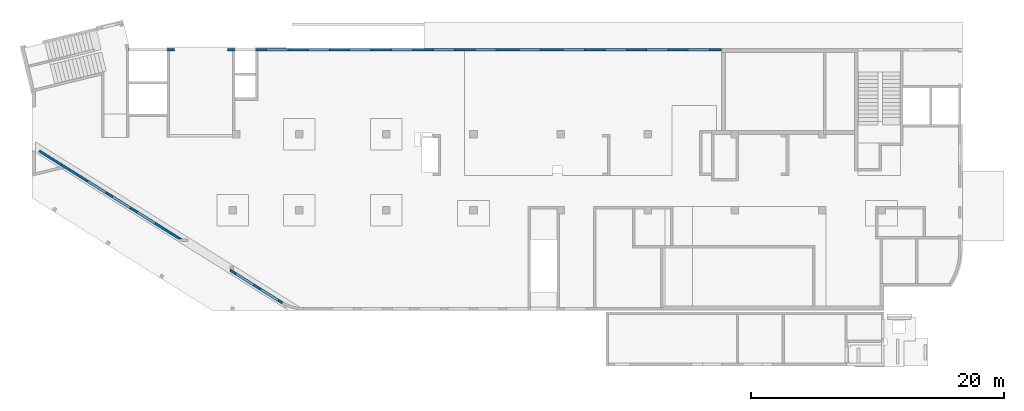
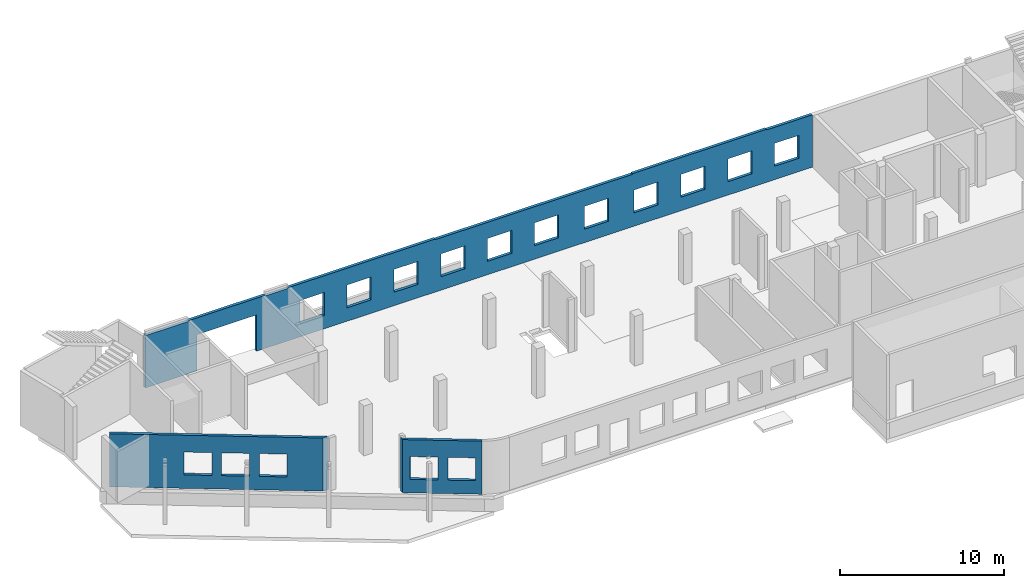
# One storey, part 6 of 8: 3 walls, 18 openings.
"""IFC4 building model written with IfcOpenShell, lengths in millimetres."""

from ifc_helpers import new_model, entity, si_unit, converted_unit, derived_unit, direction, frame, origin, place, context, subcontext, project, spatial, indexed_curve, outline, extrude, polygons, material, type_object, element, save


model = new_model("IFC4")

# Units and contexts
model_context = context("Model", 3, precision=0.01, world=origin(), true_north=direction((6.12303176911189e-17, 1.0)))
plan_context = context("Plan", 3, precision=0.01, world=origin(), true_north=direction((6.12303176911189e-17, 1.0)))
body_context = subcontext(model_context, "Body", "Model", "MODEL_VIEW")
ifc_project = project(units=[si_unit("LENGTHUNIT", "METRE", prefix="MILLI"), si_unit("AREAUNIT", "SQUARE_METRE"), si_unit("VOLUMEUNIT", "CUBIC_METRE"), converted_unit("PLANEANGLEUNIT", "DEGREE", entity("IfcRatioMeasure", 0.0174532925199433), si_unit("PLANEANGLEUNIT", "RADIAN"), dimensions=[0, 0, 0, 0, 0, 0, 0]), si_unit("MASSUNIT", "GRAM", prefix="KILO"), derived_unit("MASSDENSITYUNIT", [(si_unit("MASSUNIT", "GRAM", prefix="KILO"), 1), (si_unit("LENGTHUNIT", "METRE"), -3)]), derived_unit("MOMENTOFINERTIAUNIT", [(si_unit("LENGTHUNIT", "METRE"), 4)]), si_unit("TIMEUNIT", "SECOND"), si_unit("FREQUENCYUNIT", "HERTZ"), si_unit("THERMODYNAMICTEMPERATUREUNIT", "DEGREE_CELSIUS"), derived_unit("THERMALTRANSMITTANCEUNIT", [(si_unit("MASSUNIT", "GRAM", prefix="KILO"), 1), (si_unit("THERMODYNAMICTEMPERATUREUNIT", "KELVIN"), -1), (si_unit("TIMEUNIT", "SECOND"), -3)]), derived_unit("VOLUMETRICFLOWRATEUNIT", [(si_unit("LENGTHUNIT", "METRE"), 3), (si_unit("TIMEUNIT", "SECOND"), -1)]), derived_unit("MASSFLOWRATEUNIT", [(si_unit("MASSUNIT", "GRAM", prefix="KILO"), 1), (si_unit("TIMEUNIT", "SECOND"), -1)]), derived_unit("ROTATIONALFREQUENCYUNIT", [(si_unit("TIMEUNIT", "SECOND"), -1)]), si_unit("ELECTRICCURRENTUNIT", "AMPERE"), si_unit("ELECTRICVOLTAGEUNIT", "VOLT"), si_unit("POWERUNIT", "WATT"), si_unit("FORCEUNIT", "NEWTON", prefix="KILO"), si_unit("ILLUMINANCEUNIT", "LUX"), si_unit("LUMINOUSFLUXUNIT", "LUMEN"), si_unit("LUMINOUSINTENSITYUNIT", "CANDELA"), derived_unit("USERDEFINED", [(si_unit("MASSUNIT", "GRAM", prefix="KILO"), -1), (si_unit("LENGTHUNIT", "METRE"), -2), (si_unit("TIMEUNIT", "SECOND"), 3), (si_unit("LUMINOUSFLUXUNIT", "LUMEN"), 1)]), derived_unit("LINEARVELOCITYUNIT", [(si_unit("LENGTHUNIT", "METRE"), 1), (si_unit("TIMEUNIT", "SECOND"), -1)]), si_unit("PRESSUREUNIT", "PASCAL"), derived_unit("USERDEFINED", [(si_unit("LENGTHUNIT", "METRE"), -2), (si_unit("MASSUNIT", "GRAM", prefix="KILO"), 1), (si_unit("TIMEUNIT", "SECOND"), -2)]), derived_unit("LINEARFORCEUNIT", [(si_unit("MASSUNIT", "GRAM", prefix="KILO"), 1), (si_unit("LENGTHUNIT", "METRE"), 1), (si_unit("TIMEUNIT", "SECOND"), -2), (si_unit("LENGTHUNIT", "METRE"), -1)]), derived_unit("PLANARFORCEUNIT", [(si_unit("MASSUNIT", "GRAM", prefix="KILO"), 1), (si_unit("LENGTHUNIT", "METRE"), 1), (si_unit("TIMEUNIT", "SECOND"), -2), (si_unit("LENGTHUNIT", "METRE"), -2)])], contexts=[model_context, plan_context])

# Site, building, storey
site_placement = place(None, origin())
site = spatial("IfcSite", under=ifc_project, at=site_placement, CompositionType="ELEMENT")
building_placement = place(site_placement, origin())
building = spatial("IfcBuilding", under=site, at=building_placement, CompositionType="ELEMENT")
storey_placement = place(building_placement, origin())
storey = spatial("IfcBuildingStorey", under=building, at=storey_placement, CompositionType="ELEMENT", Elevation=0.0)

# Wall, openings
ifc_material = material()
wall_type = type_object("IfcWallType", PredefinedType="STANDARD")
wall_1_placement = place(storey_placement, frame((19848.2602920665, 354.969733530612, -150.0), z_axis=(0.0, 0.0, 1.0), x_axis=(-0.848052743777574, 0.529911826412026, 0.0)))
wall_1 = element("IfcWall", 1, at=wall_1_placement, inside=storey, type_object=wall_type, material=ifc_material, PredefinedType="NOTDEFINED", context=body_context, shape_type="Tessellation", body=[
    polygons([(0.970164127863025, -100.000000000001, 0.0), (4977.58097845414, -99.9999999999989, 0.0), (4977.58097845414, -100.0, 150.0), (4977.58097845414, -100.0, 3950.0), (0.970164127862856, -100.000000000001, 3950.0), (372.19066814268, -100.000000000001, 2700.0), (2072.19066814268, -100.000000000002, 2700.0), (2072.19066814268, -100.000000000002, 1000.00000000001), (372.19066814268, -100.000000000001, 1000.00000000001), (2672.19066814269, -100.000000000002, 2700.0), (4372.19066814268, -100.000000000004, 2700.0), (4372.19066814268, -100.000000000004, 1000.00000000001), (2672.19066814269, -100.000000000002, 1000.00000000001), (-1.50586210168058e-12, 99.9999999999996, 0.0), (-1.47202250389e-12, 99.9999999999995, 3950.0), (4852.60954706614, 99.9999999999995, 3950.0), (4852.60954706614, 99.9999999999995, 0.0), (2072.19066814268, 100.000000000317, 2700.0), (372.19066814268, 100.000000000319, 2700.0), (372.19066814268, 100.000000000319, 1000.00000000001), (2072.19066814268, 100.000000000317, 1000.00000000001), (4372.19066814269, 100.000000000316, 2700.0), (2672.19066814269, 100.000000000318, 2700.0), (2672.19066814269, 100.000000000318, 1000.00000000001), (4372.19066814269, 100.000000000316, 1000.00000000001)], [[[1, 2, 3, 4, 5], [6, 7, 8, 9], [10, 11, 12, 13]], [[14, 15, 16, 17], [18, 19, 20, 21], [22, 23, 24, 25]], [[2, 1, 14, 17]], [[5, 4, 16, 15]], [[1, 5, 15, 14]], [[4, 3, 2, 17, 16]], [[19, 18, 7, 6]], [[19, 6, 9, 20]], [[20, 9, 8, 21]], [[7, 18, 21, 8]], [[23, 22, 11, 10]], [[23, 10, 13, 24]], [[24, 13, 12, 25]], [[11, 22, 25, 12]]], closed=True),
])
opening_1_placement = place(wall_1_placement, frame((16644.2689400823, 10818.8609189489, 150.0), z_axis=(0.0, 0.0, 1.0), x_axis=(-0.848052743777574, -0.529911826412026, 0.0)))
element("IfcOpeningElement", 2, at=opening_1_placement, cuts=wall_1, PredefinedType="OPENING", context=body_context, shape_type="SweptSolid", body=[
    extrude(outline(indexed_curve([(-849.999999999994, -850.0), (849.999999999994, -850.0), (849.999999999994, 849.999999999999), (-849.999999999994, 849.999999999999), (-849.999999999994, -850.0)], self_intersect=False)), frame((16914.2480144816, 2306.22549783526, 1700.0), z_axis=(-0.529911826412028, -0.848052743777572, 0.0), x_axis=(0.0, 0.0, -1.0)), (0.0, 0.0, 1.0), 200.000000000959),
])
opening_2_placement = place(wall_1_placement, frame((16644.2689400823, 10818.8609189489, 150.0), z_axis=(0.0, 0.0, 1.0), x_axis=(-0.848052743777574, -0.529911826412026, 0.0)))
element("IfcOpeningElement", 3, at=opening_2_placement, cuts=wall_1, PredefinedType="OPENING", context=body_context, shape_type="SweptSolid", body=[
    extrude(outline(indexed_curve([(-849.999999999994, -850.0), (849.999999999994, -850.0), (849.999999999994, 850.0), (-849.999999999994, 850.0), (-849.999999999994, -850.0)], self_intersect=False)), frame((18864.76932517, 1087.42829708759, 1700.0), z_axis=(-0.529911826412028, -0.848052743777572, 0.0), x_axis=(0.0, 0.0, -1.0)), (0.0, 0.0, 1.0), 200.000000000962),
])

wall_2_placement = place(storey_placement, frame((7650.64481206478, 20399.9992263564, -150.0)))
wall_2 = element("IfcWall", 4, at=wall_2_placement, inside=storey, type_object=wall_type, material=ifc_material, PredefinedType="NOTDEFINED", context=body_context, shape_type="Tessellation", body=[
    polygons([(48.7521159583313, -99.9999999999989, 3950.0), (48.7521159583302, -99.9999999999989, 0.0), (3049.35545648991, -99.9999999999989, 0.0), (3249.35545648991, -99.9999999999989, 0.0), (3649.35545648992, -100.000000000003, 0.0), (3649.35545648992, -100.000000000003, 2699.99999999804), (7849.35545648992, -99.9999999999989, 2699.99999999804), (7849.35545648992, -99.9999999999989, 0.0), (8249.3554564899, -99.9999999999989, 0.0), (8449.3554564899, -99.9999999999989, 0.0), (10074.3554564899, -100.000000000003, 0.0), (10274.3554564899, -100.000000000003, 0.0), (46969.3554564899, -99.9999999999989, 0.0), (46969.3554564899, -99.9999999999989, 3900.0), (43739.3554564901, -99.9999999999989, 3900.0), (43739.3554564901, -99.9999999999989, 3950.0), (40119.3554564899, -99.9999999999989, 3950.0), (39819.3554564899, -99.9999999999989, 3950.0), (34319.3554564899, -99.9999999999989, 3950.0), (34319.3554564899, -99.9999999999989, 3900.0), (33919.3554564899, -99.9999999999989, 3900.0), (33619.3554564898, -99.9999999999989, 3900.0), (26769.3554564899, -99.9999999999989, 3900.0), (26469.3554564898, -99.9999999999989, 3900.0), (20419.3554564899, -99.9999999999989, 3900.0), (20419.3554564899, -99.9999999999989, 3950.0), (20119.3554564898, -99.9999999999989, 3950.0), (13219.3554564898, -99.9999999999989, 3950.0), (12919.3554564898, -100.000000000003, 3950.0), (10274.3554564899, -100.000000000003, 3950.0), (10074.3554564899, -99.9999999999989, 3950.0), (10074.3554564899, -100.000000000003, 3900.0), (8449.35545648991, -99.9999999999989, 3900.0), (8449.35545648991, -99.9999999999989, 3950.0), (8249.3554564899, -99.9999999999989, 3950.0), (7949.35545648986, -99.9999999999989, 3950.0), (3549.35545648986, -100.000000000003, 3950.0), (3249.35545648991, -99.9999999999989, 3950.0), (3049.35545648991, -99.9999999999989, 3950.0), (3049.35545648991, -99.9999999999989, 3900.0), (49.3554564899135, -99.9999999999989, 3900.0), (49.3554564899135, -99.9999999999989, 3950.0), (27419.3554564899, -100.000000000003, 2700.0), (29119.3554564899, -99.9999999999989, 2700.0), (29119.3554564899, -99.9999999999989, 1000.00000000001), (27419.3554564899, -100.000000000003, 1000.00000000001), (41019.3554564899, -99.9999999999989, 2700.0), (42719.3554564899, -99.9999999999989, 2700.0), (42719.3554564899, -99.9999999999989, 1000.00000000001), (41019.3554564899, -99.9999999999989, 1000.00000000001), (37719.3554564899, -99.9999999999989, 2700.0), (39419.3554564899, -100.000000000003, 2700.0), (39419.3554564899, -100.000000000003, 1000.00000000001), (37719.3554564899, -99.9999999999989, 1000.00000000001), (34419.3554564899, -99.9999999999946, 2700.0), (36119.3554564899, -99.9999999999989, 2700.0), (36119.3554564899, -99.9999999999989, 1000.00000000001), (34419.3554564899, -99.9999999999946, 1000.00000000001), (30919.3554564899, -99.9999999999989, 2700.0), (32619.3554564899, -99.9999999999989, 2700.0), (32619.3554564899, -99.9999999999989, 1000.00000000001), (30919.3554564899, -99.9999999999989, 1000.00000000001), (24119.3554564899, -99.9999999999989, 2700.0), (25819.3554564899, -99.9999999999989, 2700.0), (25819.3554564899, -99.9999999999989, 1000.00000000001), (24119.3554564899, -99.9999999999989, 1000.00000000001), (20819.3554564899, -100.000000000003, 2700.0), (22519.3554564899, -99.9999999999989, 2700.0), (22519.3554564899, -99.9999999999989, 1000.00000000001), (20819.3554564899, -100.000000000003, 1000.00000000001), (17519.3554564899, -99.9999999999989, 2700.0), (19219.3554564899, -100.000000000003, 2700.0), (19219.3554564899, -100.000000000003, 1000.00000000001), (17519.3554564899, -99.9999999999989, 1000.00000000001), (14219.3554564899, -100.000000000003, 2700.0), (15919.3554564899, -99.9999999999989, 2700.0), (15919.3554564899, -99.9999999999989, 1000.00000000001), (14219.3554564899, -100.000000000003, 1000.00000000001), (10919.3554564899, -99.9999999999989, 2700.0), (12619.3554564899, -99.9999999999989, 2700.0), (12619.3554564899, -99.9999999999989, 1000.00000000001), (10919.3554564899, -99.9999999999989, 1000.00000000001), (44319.3554564899, -99.9999999999989, 2700.0), (46019.3554564899, -100.000000000003, 2700.0), (46019.3554564899, -100.000000000003, 1000.00000000001), (44319.3554564899, -99.9999999999989, 1000.00000000001), (6.86477951627945e-12, 99.9999999999989, 0.0), (-7.15290388809298e-13, 99.9999999999989, 3950.0), (49.3554564899139, 99.9999999999989, 3950.0), (49.3554564899139, 99.9999999999989, 3900.0), (3049.35545648991, 99.9999999999989, 3900.0), (3049.35545648991, 99.9999999999989, 3950.0), (8449.35545648991, 99.9999999999989, 3950.0), (8449.35545648991, 99.9999999999989, 3900.0), (10074.3554564899, 99.9999999999946, 3900.0), (10074.3554564899, 99.9999999999989, 3950.0), (20419.3554564899, 99.9999999999989, 3950.0), (20419.3554564899, 99.9999999999989, 3900.0), (34319.3554564899, 99.9999999999989, 3900.0), (34319.3554564899, 99.9999999999989, 3950.0), (43739.3554564901, 99.9999999999989, 3950.0), (43739.3554564901, 99.9999999999989, 3900.0), (46969.3554564899, 99.9999999999989, 3900.0), (46969.3554564899, 99.9999999999989, 0.0), (7849.35545648992, 99.9999999999989, 0.0), (7849.35545648992, 99.9999999999989, 2699.99999999804), (3649.35545648992, 99.9999999999946, 2699.99999999804), (3649.35545648992, 99.9999999999946, 0.0), (29119.3554564899, 100.000000000324, 2700.0), (27419.3554564899, 100.000000000319, 2700.0), (27419.3554564899, 100.000000000319, 1000.00000000001), (29119.3554564899, 100.000000000324, 1000.00000000001), (42719.3554564899, 100.000000000319, 2700.0), (41019.3554564899, 100.000000000319, 2700.0), (41019.3554564899, 100.000000000319, 1000.00000000001), (42719.3554564899, 100.000000000319, 1000.00000000001), (39419.3554564899, 100.000000000319, 2700.0), (37719.3554564899, 100.000000000319, 2700.0), (37719.3554564899, 100.000000000319, 1000.00000000001), (39419.3554564899, 100.000000000319, 1000.00000000001), (36119.3554564899, 100.000000000319, 2700.0), (34419.3554564899, 100.000000000324, 2700.0), (34419.3554564899, 100.000000000324, 1000.00000000001), (36119.3554564899, 100.000000000319, 1000.00000000001), (32619.3554564899, 100.000000000319, 2700.0), (30919.3554564899, 100.000000000319, 2700.0), (30919.3554564899, 100.000000000319, 1000.00000000001), (32619.3554564899, 100.000000000319, 1000.00000000001), (25819.3554564899, 100.000000000319, 2700.0), (24119.3554564899, 100.000000000324, 2700.0), (24119.3554564899, 100.000000000324, 1000.00000000001), (25819.3554564899, 100.000000000319, 1000.00000000001), (22519.3554564899, 100.000000000319, 2700.0), (20819.3554564899, 100.000000000319, 2700.0), (20819.3554564899, 100.000000000319, 1000.00000000001), (22519.3554564899, 100.000000000319, 1000.00000000001), (19219.3554564899, 100.000000000319, 2700.0), (17519.3554564899, 100.000000000319, 2700.0), (17519.3554564899, 100.000000000319, 1000.00000000001), (19219.3554564899, 100.000000000319, 1000.00000000001), (15919.3554564899, 100.000000000319, 2700.0), (14219.3554564899, 100.000000000315, 2700.0), (14219.3554564899, 100.000000000315, 1000.00000000001), (15919.3554564899, 100.000000000319, 1000.00000000001), (12619.3554564899, 100.000000000319, 2700.0), (10919.3554564899, 100.000000000319, 2700.0), (10919.3554564899, 100.000000000319, 1000.00000000001), (12619.3554564899, 100.000000000319, 1000.00000000001), (46019.3554564899, 100.000000000315, 2700.0), (44319.3554564899, 100.000000000319, 2700.0), (44319.3554564899, 100.000000000319, 1000.00000000001), (46019.3554564899, 100.000000000315, 1000.00000000001)], [[[1, 2, 3, 4, 5, 6, 7, 8, 9, 10, 11, 12, 13, 14, 15, 16, 17, 18, 19, 20, 21, 22, 23, 24, 25, 26, 27, 28, 29, 30, 31, 32, 33, 34, 35, 36, 37, 38, 39, 40, 41, 42], [43, 44, 45, 46], [47, 48, 49, 50], [51, 52, 53, 54], [55, 56, 57, 58], [59, 60, 61, 62], [63, 64, 65, 66], [67, 68, 69, 70], [71, 72, 73, 74], [75, 76, 77, 78], [79, 80, 81, 82], [83, 84, 85, 86]], [[87, 88, 89, 90, 91, 92, 93, 94, 95, 96, 97, 98, 99, 100, 101, 102, 103, 104, 105, 106, 107, 108], [109, 110, 111, 112], [113, 114, 115, 116], [117, 118, 119, 120], [121, 122, 123, 124], [125, 126, 127, 128], [129, 130, 131, 132], [133, 134, 135, 136], [137, 138, 139, 140], [141, 142, 143, 144], [145, 146, 147, 148], [149, 150, 151, 152]], [[2, 87, 108, 5, 4, 3]], [[2, 1, 88, 87]], [[26, 25, 98, 97]], [[100, 99, 20, 19]], [[25, 24, 23, 22, 21, 20, 99, 98]], [[33, 94, 93, 34]], [[94, 33, 32, 95]], [[95, 32, 31, 96]], [[15, 14, 103, 102]], [[15, 102, 101, 16]], [[41, 90, 89, 42]], [[90, 41, 40, 91]], [[91, 40, 39, 92]], [[1, 42, 89, 88]], [[39, 38, 37, 36, 35, 34, 93, 92]], [[31, 30, 29, 28, 27, 26, 97, 96]], [[19, 18, 17, 16, 101, 100]], [[110, 109, 44, 43]], [[110, 43, 46, 111]], [[111, 46, 45, 112]], [[44, 109, 112, 45]], [[114, 113, 48, 47]], [[114, 47, 50, 115]], [[115, 50, 49, 116]], [[48, 113, 116, 49]], [[118, 117, 52, 51]], [[118, 51, 54, 119]], [[119, 54, 53, 120]], [[52, 117, 120, 53]], [[122, 121, 56, 55]], [[122, 55, 58, 123]], [[123, 58, 57, 124]], [[56, 121, 124, 57]], [[126, 125, 60, 59]], [[126, 59, 62, 127]], [[127, 62, 61, 128]], [[60, 125, 128, 61]], [[130, 129, 64, 63]], [[130, 63, 66, 131]], [[131, 66, 65, 132]], [[64, 129, 132, 65]], [[134, 133, 68, 67]], [[134, 67, 70, 135]], [[135, 70, 69, 136]], [[68, 133, 136, 69]], [[138, 137, 72, 71]], [[138, 71, 74, 139]], [[139, 74, 73, 140]], [[72, 137, 140, 73]], [[142, 141, 76, 75]], [[142, 75, 78, 143]], [[143, 78, 77, 144]], [[76, 141, 144, 77]], [[146, 145, 80, 79]], [[146, 79, 82, 147]], [[147, 82, 81, 148]], [[80, 145, 148, 81]], [[6, 107, 106, 7]], [[7, 106, 105, 8]], [[107, 6, 5, 108]], [[14, 13, 104, 103]], [[150, 149, 84, 83]], [[150, 83, 86, 151]], [[151, 86, 85, 152]], [[84, 149, 152, 85]], [[13, 12, 11, 10, 9, 8, 105, 104]]], closed=True),
])
opening_3_placement = place(wall_2_placement, origin())
element("IfcOpeningElement", 5, at=opening_3_placement, cuts=wall_2, PredefinedType="OPENING", context=body_context, shape_type="SweptSolid", body=[
    extrude(outline(indexed_curve([(-1074.99999999902, -625.000000000005), (1074.99999999902, -625.000000000005), (1074.99999999902, 624.999999999996), (-1074.99999999902, 624.999999999996), (-1074.99999999902, -625.000000000005)], self_intersect=False)), frame((62369.3554564899, -200.0, 1825.0), z_axis=(0.0, 1.0, 0.0), x_axis=(0.0, 0.0, -1.0)), (0.0, 0.0, 1.0), 400.000000001945),
])
opening_4_placement = place(wall_2_placement, frame((-7650.64481206478, -20399.9992263564, 150.0)))
element("IfcOpeningElement", 6, at=opening_4_placement, cuts=wall_2, PredefinedType="OPENING", context=body_context, shape_type="SweptSolid", body=[
    extrude(outline(indexed_curve([(-2100.0, -1349.99999999902), (2100.0, -1349.99999999902), (2100.0, 1349.99999999902), (-2100.0, 1349.99999999902), (-2100.0, -1349.99999999902)], self_intersect=False)), frame((13400.0002685547, 20199.9992263544, 1200.0), z_axis=(0.0, 1.0, 0.0), x_axis=(1.0, 0.0, 0.0)), (0.0, 0.0, 1.0), 400.000000001945),
])
opening_5_placement = place(wall_2_placement, frame((-7650.64481206478, -20399.9992263564, 150.0)))
element("IfcOpeningElement", 7, at=opening_5_placement, cuts=wall_2, PredefinedType="OPENING", context=body_context, shape_type="SweptSolid", body=[
    extrude(outline(indexed_curve([(-849.999999999994, -850.0), (849.999999999994, -850.0), (849.999999999994, 850.000000000002), (-849.999999999994, 850.000000000002), (-849.999999999994, -850.0)], self_intersect=False)), frame((19420.0002685547, 20299.9992263564, 1700.0), z_axis=(0.0, 1.0, 0.0), x_axis=(0.0, 0.0, -1.0)), (0.0, 0.0, 1.0), 200.000000000959),
])
opening_6_placement = place(wall_2_placement, frame((-7650.64481206478, -20399.9992263564, 150.0)))
element("IfcOpeningElement", 8, at=opening_6_placement, cuts=wall_2, PredefinedType="OPENING", context=body_context, shape_type="SweptSolid", body=[
    extrude(outline(indexed_curve([(-849.999999999994, -850.000000000002), (849.999999999994, -850.000000000002), (849.999999999994, 849.999999999997), (-849.999999999994, 849.999999999997), (-849.999999999994, -850.000000000002)], self_intersect=False)), frame((22720.0002685547, 20299.9992263564, 1700.0), z_axis=(0.0, 1.0, 0.0), x_axis=(0.0, 0.0, -1.0)), (0.0, 0.0, 1.0), 200.000000000959),
])
opening_7_placement = place(wall_2_placement, frame((-7650.64481206478, -20399.9992263564, 150.0)))
element("IfcOpeningElement", 9, at=opening_7_placement, cuts=wall_2, PredefinedType="OPENING", context=body_context, shape_type="SweptSolid", body=[
    extrude(outline(indexed_curve([(-849.999999999994, -850.000000000002), (849.999999999994, -850.000000000002), (849.999999999994, 849.999999999997), (-849.999999999994, 849.999999999997), (-849.999999999994, -850.000000000002)], self_intersect=False)), frame((26020.0002685547, 20299.9992263563, 1700.0), z_axis=(0.0, 1.0, 0.0), x_axis=(0.0, 0.0, -1.0)), (0.0, 0.0, 1.0), 200.000000000959),
])
opening_8_placement = place(wall_2_placement, frame((-7650.64481206478, -20399.9992263564, 150.0)))
element("IfcOpeningElement", 10, at=opening_8_placement, cuts=wall_2, PredefinedType="OPENING", context=body_context, shape_type="SweptSolid", body=[
    extrude(outline(indexed_curve([(-849.999999999994, -850.000000000002), (849.999999999994, -850.000000000002), (849.999999999994, 849.999999999997), (-849.999999999994, 849.999999999997), (-849.999999999994, -850.000000000002)], self_intersect=False)), frame((29320.0002685547, 20299.9992263563, 1700.0), z_axis=(0.0, 1.0, 0.0), x_axis=(0.0, 0.0, -1.0)), (0.0, 0.0, 1.0), 200.000000000959),
])
opening_9_placement = place(wall_2_placement, frame((-7650.64481206478, -20399.9992263564, 150.0)))
element("IfcOpeningElement", 11, at=opening_9_placement, cuts=wall_2, PredefinedType="OPENING", context=body_context, shape_type="SweptSolid", body=[
    extrude(outline(indexed_curve([(-849.999999999994, -849.999999999997), (849.999999999994, -849.999999999997), (849.999999999994, 850.000000000002), (-849.999999999994, 850.000000000002), (-849.999999999994, -849.999999999997)], self_intersect=False)), frame((32620.0002685547, 20299.9992263563, 1700.0), z_axis=(0.0, 1.0, 0.0), x_axis=(0.0, 0.0, -1.0)), (0.0, 0.0, 1.0), 200.000000000959),
])
opening_10_placement = place(wall_2_placement, frame((-7650.64481206478, -20399.9992263564, 150.0)))
element("IfcOpeningElement", 12, at=opening_10_placement, cuts=wall_2, PredefinedType="OPENING", context=body_context, shape_type="SweptSolid", body=[
    extrude(outline(indexed_curve([(-849.999999999994, -849.999999999997), (849.999999999994, -849.999999999997), (849.999999999994, 850.000000000006), (-849.999999999994, 850.000000000006), (-849.999999999994, -849.999999999997)], self_intersect=False)), frame((39420.0002685547, 20299.9992263563, 1700.0), z_axis=(0.0, 1.0, 0.0), x_axis=(0.0, 0.0, -1.0)), (0.0, 0.0, 1.0), 200.000000000959),
])
opening_11_placement = place(wall_2_placement, frame((-7650.64481206478, -20399.9992263564, 150.0)))
element("IfcOpeningElement", 13, at=opening_11_placement, cuts=wall_2, PredefinedType="OPENING", context=body_context, shape_type="SweptSolid", body=[
    extrude(outline(indexed_curve([(-849.999999999994, -850.000000000006), (849.999999999994, -850.000000000006), (849.999999999994, 849.999999999997), (-849.999999999994, 849.999999999997), (-849.999999999994, -850.000000000006)], self_intersect=False)), frame((42920.0002685547, 20299.9992263563, 1700.0), z_axis=(0.0, 1.0, 0.0), x_axis=(0.0, 0.0, -1.0)), (0.0, 0.0, 1.0), 200.000000000959),
])
opening_12_placement = place(wall_2_placement, frame((-7650.64481206478, -20399.9992263564, 150.0)))
element("IfcOpeningElement", 14, at=opening_12_placement, cuts=wall_2, PredefinedType="OPENING", context=body_context, shape_type="SweptSolid", body=[
    extrude(outline(indexed_curve([(-849.999999999994, -850.000000000006), (849.999999999994, -850.000000000006), (849.999999999994, 849.999999999997), (-849.999999999994, 849.999999999997), (-849.999999999994, -850.000000000006)], self_intersect=False)), frame((46220.0002685547, 20299.9992263563, 1700.0), z_axis=(0.0, 1.0, 0.0), x_axis=(0.0, 0.0, -1.0)), (0.0, 0.0, 1.0), 200.000000000959),
])
opening_13_placement = place(wall_2_placement, frame((-7650.64481206478, -20399.9992263564, 150.0)))
element("IfcOpeningElement", 15, at=opening_13_placement, cuts=wall_2, PredefinedType="OPENING", context=body_context, shape_type="SweptSolid", body=[
    extrude(outline(indexed_curve([(-849.999999999994, -849.999999999997), (849.999999999994, -849.999999999997), (849.999999999994, 850.000000000006), (-849.999999999994, 850.000000000006), (-849.999999999994, -849.999999999997)], self_intersect=False)), frame((49520.0002685547, 20299.9992263563, 1700.0), z_axis=(0.0, 1.0, 0.0), x_axis=(0.0, 0.0, -1.0)), (0.0, 0.0, 1.0), 200.000000000959),
])
opening_14_placement = place(wall_2_placement, frame((-7650.64481206478, -20399.9992263564, 150.0)))
element("IfcOpeningElement", 16, at=opening_14_placement, cuts=wall_2, PredefinedType="OPENING", context=body_context, shape_type="SweptSolid", body=[
    extrude(outline(indexed_curve([(-849.999999999994, -849.999999999997), (849.999999999994, -849.999999999997), (849.999999999994, 850.000000000002), (-849.999999999994, 850.000000000002), (-849.999999999994, -849.999999999997)], self_intersect=False)), frame((35920.0002685547, 20299.9992263563, 1700.0), z_axis=(0.0, 1.0, 0.0), x_axis=(0.0, 0.0, -1.0)), (0.0, 0.0, 1.0), 200.000000000959),
])
opening_15_placement = place(wall_2_placement, frame((-7650.64481206478, -20399.9992263564, 150.0)))
element("IfcOpeningElement", 17, at=opening_15_placement, cuts=wall_2, PredefinedType="OPENING", context=body_context, shape_type="SweptSolid", body=[
    extrude(outline(indexed_curve([(-849.999999999994, -850.000000000006), (849.999999999994, -850.000000000006), (849.999999999994, 849.999999999997), (-849.999999999994, 849.999999999997), (-849.999999999994, -850.000000000006)], self_intersect=False)), frame((52820.0002685547, 20299.9992263563, 1700.0), z_axis=(0.0, 1.0, 0.0), x_axis=(0.0, 0.0, -1.0)), (0.0, 0.0, 1.0), 200.000000000959),
])

wall_3_placement = place(storey_placement, frame((11910.0872818721, 5315.19395197861, -150.0), z_axis=(0.0, 0.0, 1.0), x_axis=(-0.848052743777574, 0.529911826412026, 0.0)))
wall_3 = element("IfcWall", 18, at=wall_3_placement, inside=storey, type_object=wall_type, material=ifc_material, PredefinedType="NOTDEFINED", context=body_context, shape_type="Tessellation", body=[
    polygons([(-1.08286712929839e-12, -99.9999999999989, 0.0), (13350.7623325176, -99.9999999999989, 0.0), (13350.7623325176, -99.9999999999989, 3950.0), (-1.62430069394759e-12, -99.9999999999978, 3950.0), (2511.71979125528, -100.000000000009, 2700.0), (4211.71979125528, -100.000000000012, 2700.0), (4211.71979125528, -100.000000000012, 1000.00000000001), (2511.71979125528, -100.000000000009, 1000.00000000001), (4811.71979125528, -100.000000000013, 2700.0), (6511.71979125528, -100.000000000015, 2700.0), (6511.71979125528, -100.000000000015, 1000.00000000001), (4811.71979125528, -100.000000000013, 1000.00000000001), (7111.71979125529, -100.000000000014, 2700.0), (8811.71979125529, -100.000000000016, 2700.0), (8811.71979125529, -100.000000000016, 1000.00000000001), (7111.71979125529, -100.000000000014, 1000.00000000001), (13350.7623325176, 100.000000000001, 0.0), (320.073152365613, 100.0, 0.0), (320.073152365612, 100.000000000001, 3950.0), (10922.962351163, 100.0, 3950.0), (11202.4176589652, 100.0, 3950.0), (13350.7623325176, 100.000000000001, 3950.0), (4211.71979125528, 100.000000000309, 2700.0), (2511.71979125528, 100.00000000031, 2700.0), (2511.71979125528, 100.00000000031, 1000.00000000001), (4211.71979125528, 100.000000000309, 1000.00000000001), (6511.71979125528, 100.000000000306, 2700.0), (4811.71979125528, 100.000000000309, 2700.0), (4811.71979125528, 100.000000000309, 1000.00000000001), (6511.71979125528, 100.000000000305, 1000.00000000001), (8811.71979125529, 100.000000000304, 2700.0), (7111.71979125529, 100.000000000304, 2700.0), (7111.71979125529, 100.000000000304, 1000.00000000001), (8811.71979125529, 100.000000000304, 1000.00000000001)], [[[1, 2, 3, 4], [5, 6, 7, 8], [9, 10, 11, 12], [13, 14, 15, 16]], [[17, 18, 19, 20, 21, 22], [23, 24, 25, 26], [27, 28, 29, 30], [31, 32, 33, 34]], [[2, 1, 18, 17]], [[3, 2, 17, 22]], [[4, 3, 22, 21, 20, 19]], [[1, 4, 19, 18]], [[24, 23, 6, 5]], [[24, 5, 8, 25]], [[25, 8, 7, 26]], [[6, 23, 26, 7]], [[28, 27, 10, 9]], [[28, 9, 12, 29]], [[29, 12, 11, 30]], [[10, 27, 30, 11]], [[32, 31, 14, 13]], [[32, 13, 16, 33]], [[33, 16, 15, 34]], [[14, 31, 34, 15]]], closed=True),
])
opening_16_placement = place(wall_3_placement, frame((7283.79806319486, 10818.8609189489, 150.0), z_axis=(0.0, 0.0, 1.0), x_axis=(-0.848052743777574, -0.529911826412026, 0.0)))
element("IfcOpeningElement", 19, at=opening_16_placement, cuts=wall_3, PredefinedType="OPENING", context=body_context, shape_type="SweptSolid", body=[
    extrude(outline(indexed_curve([(-849.999999999994, -850.0), (849.999999999994, -850.0), (849.999999999994, 850.0), (-849.999999999994, 850.0), (-849.999999999994, -850.0)], self_intersect=False)), frame((5211.12015035104, 9619.00870232127, 1700.0), z_axis=(-0.529911826412028, -0.848052743777572, 0.0), x_axis=(0.0, 0.0, -1.0)), (0.0, 0.0, 1.0), 200.000000000964),
])
opening_17_placement = place(wall_3_placement, frame((7283.79806319486, 10818.8609189489, 150.0), z_axis=(0.0, 0.0, 1.0), x_axis=(-0.848052743777574, -0.529911826412026, 0.0)))
element("IfcOpeningElement", 20, at=opening_17_placement, cuts=wall_3, PredefinedType="OPENING", context=body_context, shape_type="SweptSolid", body=[
    extrude(outline(indexed_curve([(-849.999999999994, -850.0), (849.999999999994, -850.0), (849.999999999994, 850.0), (-849.999999999994, 850.0), (-849.999999999994, -850.0)], self_intersect=False)), frame((7161.64146103947, 8400.2115015736, 1700.0), z_axis=(-0.529911826412028, -0.848052743777572, 0.0), x_axis=(0.0, 0.0, -1.0)), (0.0, 0.0, 1.0), 200.000000000964),
])
opening_18_placement = place(wall_3_placement, frame((7283.79806319486, 10818.8609189489, 150.0), z_axis=(0.0, 0.0, 1.0), x_axis=(-0.848052743777574, -0.529911826412026, 0.0)))
element("IfcOpeningElement", 21, at=opening_18_placement, cuts=wall_3, PredefinedType="OPENING", context=body_context, shape_type="SweptSolid", body=[
    extrude(outline(indexed_curve([(-849.999999999994, -850.0), (849.999999999994, -850.0), (849.999999999994, 850.0), (-849.999999999994, 850.0), (-849.999999999994, -850.0)], self_intersect=False)), frame((9112.16277172788, 7181.41430082593, 1700.0), z_axis=(-0.529911826412028, -0.848052743777572, 0.0), x_axis=(0.0, 0.0, -1.0)), (0.0, 0.0, 1.0), 200.000000000962),
])

save(model, "model.ifc")
